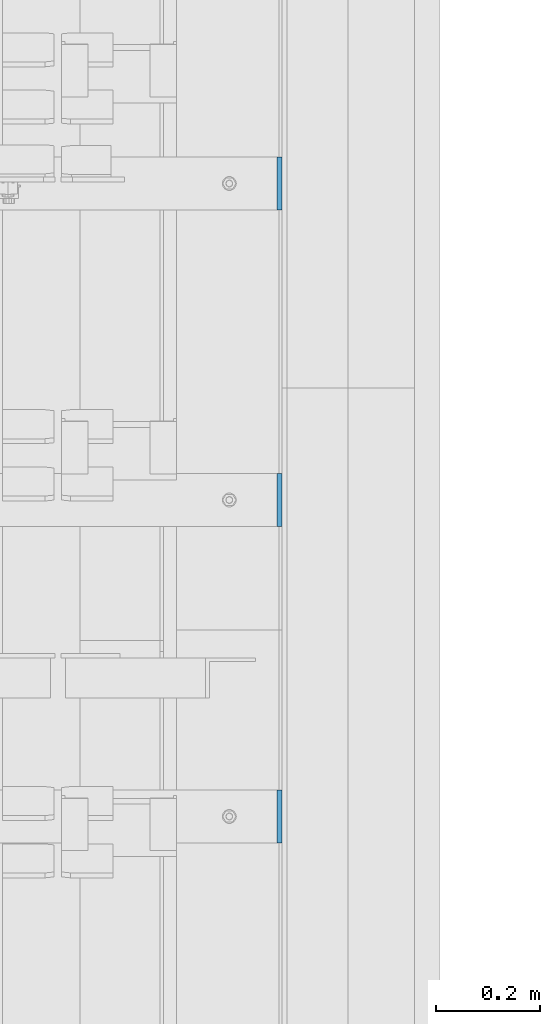
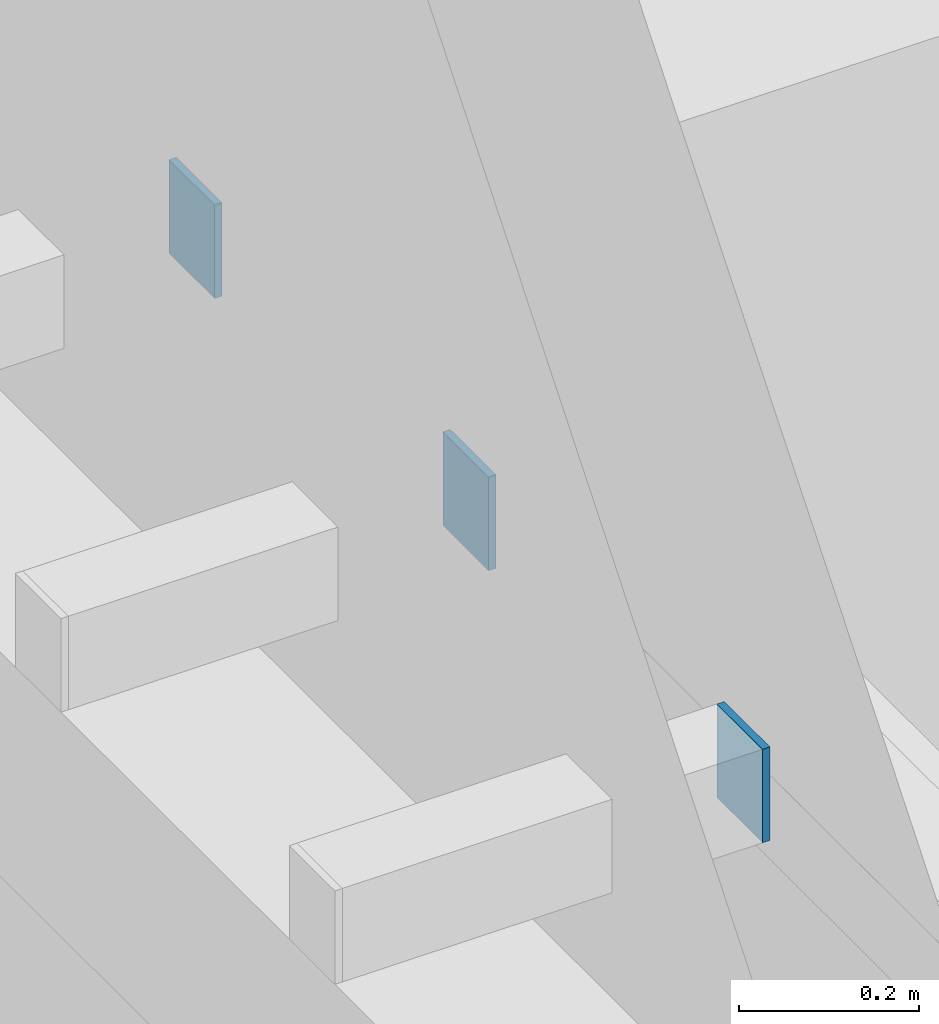
# One storey, part 451 of 1179: 3 columns, 3 elements without a shape of their own.
"""IFC2X3 building model written with IfcOpenShell, lengths in millimetres."""

from ifc_helpers import new_model, si_unit, frame, origin_with_axes, place, context, subcontext, project, spatial, faceted_brep, material, type_object, element, aggregate, save


model = new_model("IFC2X3")

# Units and contexts
model_context = context("Model", 3, precision=1e-05, world=origin_with_axes())
body_context = subcontext(model_context, "Body", "Model", "MODEL_VIEW")
ifc_project = project(units=[si_unit("LENGTHUNIT", "METRE", prefix="MILLI"), si_unit("AREAUNIT", "SQUARE_METRE"), si_unit("VOLUMEUNIT", "CUBIC_METRE"), si_unit("MASSUNIT", "GRAM", prefix="KILO"), si_unit("TIMEUNIT", "SECOND"), si_unit("PLANEANGLEUNIT", "RADIAN"), si_unit("SOLIDANGLEUNIT", "STERADIAN"), si_unit("THERMODYNAMICTEMPERATUREUNIT", "DEGREE_CELSIUS"), si_unit("LUMINOUSINTENSITYUNIT", "LUMEN")], contexts=[model_context])

# Site, building, storey
site_placement = place(None, origin_with_axes())
site = spatial("IfcSite", under=ifc_project, at=site_placement, CompositionType="ELEMENT")
building_placement = place(site_placement, origin_with_axes())
building = spatial("IfcBuilding", under=site, at=building_placement, Name="Undefined", CompositionType="ELEMENT")
storey_placement = place(building_placement, origin_with_axes())
storey = spatial("IfcBuildingStorey", under=building, at=storey_placement, Name="Undefined", CompositionType="ELEMENT", Elevation=0.0)

# Assembly, column
assembly_1_placement = place(storey_placement, origin_with_axes())
assembly_1 = element("IfcElementAssembly", 1, at=assembly_1_placement, inside=storey, Name="BEAM", AssemblyPlace="NOTDEFINED", PredefinedType="RIGID_FRAME")
ifc_material = material(Name="STEEL/A36")
column_type = type_object("IfcColumnType", PredefinedType="NOTDEFINED")
column_1_placement = place(assembly_1_placement, frame((24734.8375, 23139.4, 8013.69999998781), z_axis=(0.0, 1.0, 0.0), x_axis=(0.0, 0.0, 1.0)))
column_1 = element("IfcColumn", 2, at=column_1_placement, type_object=column_type, material=ifc_material, Name="PLATE", context=body_context, shape_type="Brep", body=[
    faceted_brep([(0.0, 4.76249999999982, -50.7999999999993), (0.0, 4.76249999999982, 50.7999999999993), (127.000000000371, 4.76249999928405, 50.8000000000002), (127.000000000371, 4.76249999928405, -50.8000000000002), (0.0, -4.76249999999982, 50.7999999999993), (127.0, -4.76250000000073, 50.7999999999993), (0.0, -4.76249999999982, -50.7999999999993), (127.0, -4.76250000000073, -50.7999999999993)], [[[0, 1, 2, 3]], [[1, 4, 5, 2]], [[4, 6, 7, 5]], [[6, 0, 3, 7]], [[5, 7, 3, 2]], [[6, 4, 1, 0]]]),
])
aggregate(assembly_1, [column_1])

assembly_2_placement = place(storey_placement, origin_with_axes())
assembly_2 = element("IfcElementAssembly", 3, at=assembly_2_placement, inside=storey, Name="BEAM", AssemblyPlace="NOTDEFINED", PredefinedType="RIGID_FRAME")
column_2_placement = place(assembly_2_placement, frame((24734.8375, 22529.8, 8013.69999998781), z_axis=(0.0, 1.0, 0.0), x_axis=(0.0, 0.0, 1.0)))
column_2 = element("IfcColumn", 4, at=column_2_placement, type_object=column_type, material=ifc_material, Name="PLATE", context=body_context, shape_type="Brep", body=[
    faceted_brep([(0.0, 4.76249999999982, -50.7999999999993), (0.0, 4.76249999999982, 50.7999999999993), (127.000000000371, 4.76249999928405, 50.8000000000002), (127.000000000371, 4.76249999928405, -50.8000000000002), (0.0, -4.76249999999982, 50.7999999999993), (127.0, -4.76250000000073, 50.7999999999993), (0.0, -4.76249999999982, -50.7999999999993), (127.0, -4.76250000000073, -50.7999999999993)], [[[0, 1, 2, 3]], [[1, 4, 5, 2]], [[4, 6, 7, 5]], [[6, 0, 3, 7]], [[5, 7, 3, 2]], [[6, 4, 1, 0]]]),
])
aggregate(assembly_2, [column_2])

assembly_3_placement = place(storey_placement, origin_with_axes())
assembly_3 = element("IfcElementAssembly", 5, at=assembly_3_placement, inside=storey, Name="BEAM", AssemblyPlace="NOTDEFINED", PredefinedType="RIGID_FRAME")
column_3_placement = place(assembly_3_placement, frame((24734.8375, 21920.2, 8013.69999998781), z_axis=(0.0, 1.0, 0.0), x_axis=(0.0, 0.0, 1.0)))
column_3 = element("IfcColumn", 6, at=column_3_placement, type_object=column_type, material=ifc_material, Name="PLATE", context=body_context, shape_type="Brep", body=[
    faceted_brep([(0.0, 4.76249999999982, -50.7999999999993), (0.0, 4.76249999999982, 50.7999999999993), (127.000000000371, 4.76249999928405, 50.8000000000002), (127.000000000371, 4.76249999928405, -50.8000000000002), (0.0, -4.76249999999982, 50.7999999999993), (127.0, -4.76250000000073, 50.7999999999993), (0.0, -4.76249999999982, -50.7999999999993), (127.0, -4.76250000000073, -50.7999999999993)], [[[0, 1, 2, 3]], [[1, 4, 5, 2]], [[4, 6, 7, 5]], [[6, 0, 3, 7]], [[5, 7, 3, 2]], [[6, 4, 1, 0]]]),
])
aggregate(assembly_3, [column_3])

save(model, "model.ifc")
